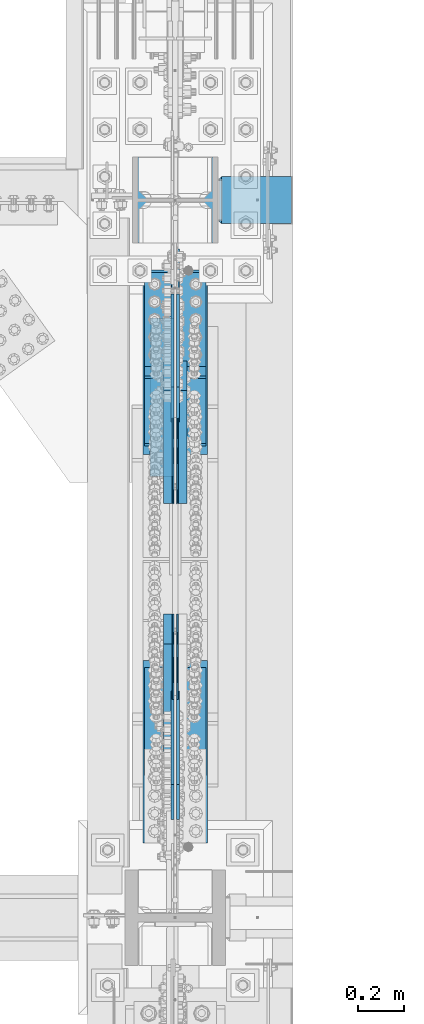
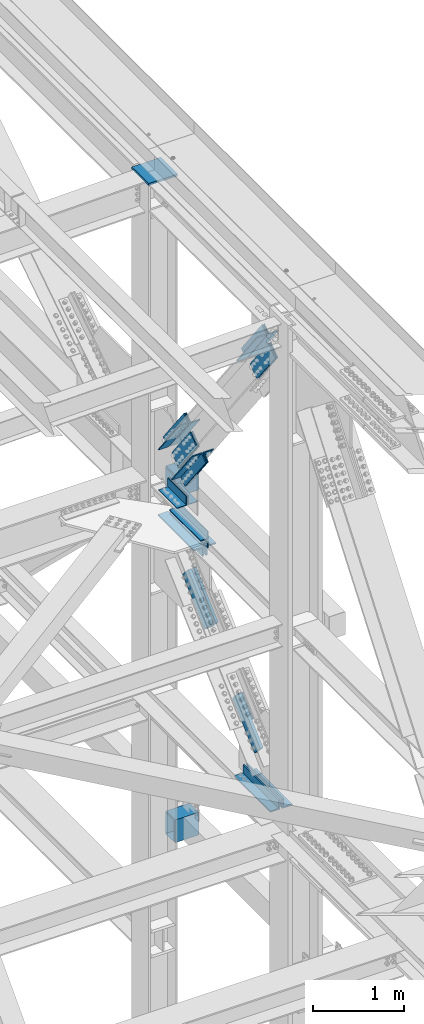
# One storey, part 2776 of 3843: 17 members, 11 beams, 10 elements without a shape of their own.
"""IFC2X3 building model written with IfcOpenShell, lengths in millimetres."""

from ifc_helpers import new_model, si_unit, frame, origin_with_axes, place, context, subcontext, project, spatial, faceted_brep, material, type_object, element, aggregate, save


model = new_model("IFC2X3")

# Units and contexts
model_context = context("Model", 3, precision=1e-05, world=origin_with_axes())
body_context = subcontext(model_context, "Body", "Model", "MODEL_VIEW")
ifc_project = project(units=[si_unit("LENGTHUNIT", "METRE", prefix="MILLI"), si_unit("AREAUNIT", "SQUARE_METRE"), si_unit("VOLUMEUNIT", "CUBIC_METRE"), si_unit("MASSUNIT", "GRAM", prefix="KILO"), si_unit("TIMEUNIT", "SECOND"), si_unit("PLANEANGLEUNIT", "RADIAN"), si_unit("SOLIDANGLEUNIT", "STERADIAN"), si_unit("THERMODYNAMICTEMPERATUREUNIT", "DEGREE_CELSIUS"), si_unit("LUMINOUSINTENSITYUNIT", "LUMEN")], contexts=[model_context])

# Site, building, storey
site_placement = place(None, origin_with_axes())
site = spatial("IfcSite", under=ifc_project, at=site_placement, CompositionType="ELEMENT")
building_placement = place(site_placement, origin_with_axes())
building = spatial("IfcBuilding", under=site, at=building_placement, Name="Undefined", CompositionType="ELEMENT")
storey_placement = place(building_placement, origin_with_axes())
storey = spatial("IfcBuildingStorey", under=building, at=storey_placement, Name="Undefined", CompositionType="ELEMENT", Elevation=0.0)

# Assembly, beam
assembly_1_placement = place(storey_placement, origin_with_axes())
assembly_1 = element("IfcElementAssembly", 1, at=assembly_1_placement, inside=storey, Name="PLATE", AssemblyPlace="NOTDEFINED", PredefinedType="RIGID_FRAME")
ifc_material_1 = material(Name="STEEL/A572-50")
beam_type_1 = type_object("IfcBeamType", Name="L4X4X1/2", PredefinedType="NOTDEFINED")
beam_1_placement = place(assembly_1_placement, frame((85591.650000015, 91020.9, 42297.3494995117), z_axis=(-1.0, 0.0, 0.0), x_axis=(0.0, 1.0, 0.0)))
beam_1 = element("IfcBeam", 2, at=beam_1_placement, type_object=beam_type_1, material=ifc_material_1, Name="ANGLE", ObjectType="L4X4X1/2", context=body_context, shape_type="Brep", body=[
    faceted_brep([(0.0, 50.8000000000029, -50.8000000000029), (0.0, 50.8000000000029, 50.8000000000029), (685.800000000003, 50.8000000000029, 50.8000000000029), (685.800000000003, 50.8000000000029, -50.8000000000029), (0.0, 38.0999999999985, 50.8000000000029), (685.800000000003, 38.0999999999985, 50.8000000000029), (0.0, 38.0999999999985, -38.0999999999985), (685.800000000003, 38.0999999999985, -38.1000000000058), (0.0, -50.8000000000029, -38.1000000000058), (685.800000000003, -50.8000000000029, -38.1000000000058), (0.0, -50.8000000000029, -50.8000000000029), (685.800000000003, -50.8000000000029, -50.8000000000029)], [[[0, 1, 2, 3]], [[1, 4, 5, 2]], [[4, 6, 7, 5]], [[6, 8, 9, 7]], [[8, 10, 11, 9]], [[10, 0, 3, 11]], [[5, 7, 9, 11, 3, 2]], [[10, 8, 6, 4, 1, 0]]]),
])

# Assembly, beams
assembly_2_placement = place(storey_placement, origin_with_axes())
assembly_2 = element("IfcElementAssembly", 3, at=assembly_2_placement, inside=storey, Name="COLUMN", AssemblyPlace="NOTDEFINED", PredefinedType="RIGID_FRAME")
ifc_material_2 = material()
beam_type_2 = type_object("IfcBeamType", Name="HSS12X8X3/8", PredefinedType="NOTDEFINED")
beam_2_placement = place(assembly_2_placement, frame((85832.95, 92214.7, 42214.8), z_axis=(0.0, 0.0, 1.0), x_axis=(1.0, 0.0, 0.0)))
beam_2 = element("IfcBeam", 4, at=beam_2_placement, type_object=beam_type_2, material=ifc_material_2, Name="GIRT", ObjectType="HSS12X8X3/8", context=body_context, shape_type="Brep", body=[
    faceted_brep([(15.8750001309381, 101.600000000006, 152.399999999972), (15.8749984899478, 101.600000000006, -152.400000000031), (6.35000000002037, 92.0749999999971, -142.875), (6.35000000002037, 92.0749999999971, 142.875), (15.8749984899478, -101.600000000006, -152.400000000031), (6.35000000002037, -92.0749999999971, -142.875), (15.8750001044536, -101.600000052975, 152.399999973481), (6.35000000002037, -92.0749999999971, 142.875), (317.499999999971, -101.599999999999, 152.400000000001), (317.499999999971, 101.599999999999, 152.400000000001), (317.499999999971, -101.599999999999, -152.400000000001), (317.499999999971, 101.599999999999, -152.400000000001), (317.499999999971, -92.0750000000007, 142.875), (317.499999999971, 92.0750000000007, 142.875), (317.499999999971, 92.0750000000007, -142.875), (317.499999999971, -92.0750000000007, -142.875)], [[[0, 1, 2, 3]], [[4, 5, 2, 1]], [[6, 7, 5, 4]], [[8, 9, 0, 6]], [[10, 8, 6, 4]], [[11, 10, 4, 1]], [[9, 11, 1, 0]], [[8, 10, 11, 9], [12, 13, 14, 15]], [[14, 13, 3, 2]], [[15, 14, 2, 5]], [[12, 15, 5, 7]], [[13, 12, 7, 3]], [[0, 3, 7, 6]]]),
])
beam_3_placement = place(assembly_2_placement, frame((85832.95, 92214.7, 37592.0), z_axis=(0.0, 0.0, 1.0), x_axis=(1.0, 0.0, 0.0)))
beam_3 = element("IfcBeam", 5, at=beam_3_placement, type_object=beam_type_2, material=ifc_material_2, Name="BEAM", ObjectType="HSS12X8X3/8", context=body_context, shape_type="Brep", body=[
    faceted_brep([(15.8750001309381, 101.600000000006, 152.399999999972), (15.8749984899478, 101.600000000006, -152.400000000031), (6.35000000002037, 92.0749999999971, -142.875), (6.35000000002037, 92.0749999999971, 142.875), (15.8749984899478, -101.600000000006, -152.400000000031), (6.35000000002037, -92.0749999999971, -142.875), (15.8750001044536, -101.600000052975, 152.399999973481), (6.35000000002037, -92.0749999999971, 142.875), (317.499999999971, -101.599999999999, 152.400000000001), (317.499999999971, 101.599999999999, 152.400000000001), (317.499999999971, -101.599999999999, -152.400000000001), (317.499999999971, 101.599999999999, -152.400000000001), (317.499999999971, -92.0750000000007, 142.875), (317.499999999971, 92.0750000000007, 142.875), (317.499999999971, 92.0750000000007, -142.875), (317.499999999971, -92.0750000000007, -142.875)], [[[0, 1, 2, 3]], [[4, 5, 2, 1]], [[6, 7, 5, 4]], [[8, 9, 0, 6]], [[10, 8, 6, 4]], [[11, 10, 4, 1]], [[9, 11, 1, 0]], [[8, 10, 11, 9], [12, 13, 14, 15]], [[14, 13, 3, 2]], [[15, 14, 2, 5]], [[12, 15, 5, 7]], [[13, 12, 7, 3]], [[0, 3, 7, 6]]]),
])

# Beam
beam_type_3 = type_object("IfcBeamType", Name="L4X3-1/2X1/2", PredefinedType="NOTDEFINED")
beam_4_placement = place(assembly_1_placement, frame((85591.6500000149, 91706.7, 42173.5244995117), z_axis=(-1.0, 0.0, 0.0), x_axis=(0.0, -1.0, 0.0)))
beam_4 = element("IfcBeam", 6, at=beam_4_placement, type_object=beam_type_3, material=ifc_material_1, Name="ANGLE", ObjectType="L4X3-1/2X1/2", context=body_context, shape_type="Brep", body=[
    faceted_brep([(0.0, 44.4499999999971, -50.8000000000029), (0.0, 44.4499999999971, 50.8000000000029), (685.800000000003, 44.4499999999971, 50.8000000000029), (685.800000000003, 44.4499999999971, -50.8000000000029), (0.0, 31.75, 50.8000000000029), (685.800000000003, 31.75, 50.8000000000029), (0.0, 31.7500000838336, -38.0999999999985), (685.800000000003, 31.75, -38.0999999999985), (4.36557456851006e-11, -44.4500000000226, -38.0999999999985), (685.800000000003, -44.4499999999971, -38.0999999999985), (0.0, -44.4499999999971, -50.8000000000029), (685.800000000003, -44.4499999999971, -50.8000000000029)], [[[0, 1, 2, 3]], [[1, 4, 5, 2]], [[4, 6, 7, 5]], [[6, 8, 9, 7]], [[8, 10, 11, 9]], [[10, 0, 3, 11]], [[5, 7, 9, 11, 3, 2]], [[10, 8, 6, 4, 1, 0]]]),
])

aggregate(assembly_1, [beam_4, beam_1])

# Assembly, members
assembly_3_placement = place(storey_placement, origin_with_axes())
assembly_3 = element("IfcElementAssembly", 7, at=assembly_3_placement, inside=storey, AssemblyPlace="NOTDEFINED", PredefinedType="RIGID_FRAME")
member_type_1 = type_object("IfcMemberType", PredefinedType="NOTDEFINED")
member_1_placement = place(assembly_3_placement, frame((85617.0500002308, 89873.9391315324, 40116.841340106), z_axis=(0.0, -0.672974507774418, 0.739665675752079), x_axis=(0.0, 0.739665675752077, 0.672974507774421)))
member_1 = element("IfcMember", 8, at=member_1_placement, type_object=member_type_1, material=ifc_material_1, Name="PLATE", context=body_context, shape_type="Brep", body=[
    faceted_brep([(1.16415321826935e-10, 19.0500000000029, -95.2500000001601), (-1.16415321826935e-10, 19.0500000000029, 95.2500000001601), (660.400000008245, 19.0500000000029, 95.2500000025429), (660.400000007954, 19.0500000000029, -95.2499999980901), (-1.16415321826935e-10, -19.0500000000029, 95.2500000001601), (660.400000008245, -19.0500000000029, 95.2500000025429), (1.16415321826935e-10, -19.0500000000029, -95.2500000001601), (660.400000007954, -19.0500000000029, -95.2499999980901)], [[[0, 1, 2, 3]], [[1, 4, 5, 2]], [[4, 6, 7, 5]], [[6, 0, 3, 7]], [[5, 7, 3, 2]], [[6, 4, 1, 0]]]),
])
member_2_placement = place(assembly_3_placement, frame((85680.5500002308, 91456.6608715596, 41556.8586598832), z_axis=(0.0, 0.672974507774426, -0.739665675752072), x_axis=(0.0, -0.739665675752075, -0.672974507774422)))
member_2 = element("IfcMember", 9, at=member_2_placement, type_object=member_type_1, material=ifc_material_1, Name="PLATE", context=body_context, shape_type="Brep", body=[
    faceted_brep([(1.16415321826935e-10, 19.0500000000029, -95.2500000001601), (-1.16415321826935e-10, 19.0500000000029, 95.2500000001601), (660.400000008245, 19.0500000000029, 95.2500000025429), (660.400000007954, 19.0500000000029, -95.2499999980901), (-1.16415321826935e-10, -19.0500000000029, 95.2500000001601), (660.400000008245, -19.0500000000029, 95.2500000025429), (1.16415321826935e-10, -19.0500000000029, -95.2500000001601), (660.400000007954, -19.0500000000029, -95.2499999980901)], [[[0, 1, 2, 3]], [[1, 4, 5, 2]], [[4, 6, 7, 5]], [[6, 0, 3, 7]], [[5, 7, 3, 2]], [[6, 4, 1, 0]]]),
])
member_3_placement = place(assembly_3_placement, frame((85617.0500002308, 91456.6608715596, 41556.8586598832), z_axis=(0.0, 0.672974507774426, -0.739665675752072), x_axis=(0.0, -0.739665675752075, -0.672974507774422)))
member_3 = element("IfcMember", 10, at=member_3_placement, type_object=member_type_1, material=ifc_material_1, Name="PLATE", context=body_context, shape_type="Brep", body=[
    faceted_brep([(1.16415321826935e-10, 19.0500000000029, -95.2500000001601), (-1.16415321826935e-10, 19.0500000000029, 95.2500000001601), (660.400000008245, 19.0500000000029, 95.2500000025429), (660.400000007954, 19.0500000000029, -95.2499999980901), (-1.16415321826935e-10, -19.0500000000029, 95.2500000001601), (660.400000008245, -19.0500000000029, 95.2500000025429), (1.16415321826935e-10, -19.0500000000029, -95.2500000001601), (660.400000007954, -19.0500000000029, -95.2499999980901)], [[[0, 1, 2, 3]], [[1, 4, 5, 2]], [[4, 6, 7, 5]], [[6, 0, 3, 7]], [[5, 7, 3, 2]], [[6, 4, 1, 0]]]),
])

assembly_4_placement = place(storey_placement, origin_with_axes())
assembly_4 = element("IfcElementAssembly", 11, at=assembly_4_placement, inside=storey, AssemblyPlace="NOTDEFINED", PredefinedType="RIGID_FRAME")
member_type_2 = type_object("IfcMemberType", Name="L5X5X1/2", PredefinedType="NOTDEFINED")
member_4_placement = place(assembly_4_placement, frame((85718.6499996898, 91570.2075713451, 42688.2572103369), z_axis=(0.0, -0.792438093282077, -0.609952349217106), x_axis=(0.0, -0.609952349217105, 0.792438093282078)))
member_4 = element("IfcMember", 12, at=member_4_placement, type_object=member_type_2, material=ifc_material_1, Name="ANGLE", ObjectType="L5X5X1/2", context=body_context, shape_type="Brep", body=[
    faceted_brep([(-1.01863406598568e-10, 63.5, -63.5000000002037), (1.01863406598568e-10, 63.5, 63.5000000002074), (749.300000016152, 63.5, 63.4999999992142), (749.300000016028, 63.5, -63.5000000006548), (1.01863406598568e-10, 50.8000000000029, 63.5000000002074), (749.300000016152, 50.8000000000029, 63.4999999992142), (0.0, 50.8000000000029, -50.8000000000029), (749.30000001605, 50.8000000000029, -50.8000000006577), (-7.27595761418343e-11, -63.5, -50.8000000001666), (749.30000001605, -63.5, -50.8000000006577), (-1.01863406598568e-10, -63.5, -63.5000000002037), (749.300000016028, -63.5, -63.5000000006548)], [[[0, 1, 2, 3]], [[1, 4, 5, 2]], [[4, 6, 7, 5]], [[6, 8, 9, 7]], [[8, 10, 11, 9]], [[10, 0, 3, 11]], [[5, 7, 9, 11, 3, 2]], [[10, 8, 6, 4, 1, 0]]]),
])
member_5_placement = place(assembly_4_placement, frame((85718.6499996898, 91495.6008998966, 43576.3940773595), z_axis=(0.0, 0.792438093282068, 0.609952349217117), x_axis=(0.0, 0.6099523492171, -0.792438093282081)))
member_5 = element("IfcMember", 13, at=member_5_placement, type_object=member_type_2, material=ifc_material_1, Name="ANGLE", ObjectType="L5X5X1/2", context=body_context, shape_type="Brep", body=[
    faceted_brep([(-1.01863406598568e-10, 63.5, -63.5000000002037), (1.01863406598568e-10, 63.5, 63.5000000002074), (749.300000016152, 63.5, 63.4999999992142), (749.300000016028, 63.5, -63.5000000006548), (1.01863406598568e-10, 50.8000000000029, 63.5000000002074), (749.300000016152, 50.8000000000029, 63.4999999992142), (0.0, 50.8000000000029, -50.8000000000029), (749.30000001605, 50.8000000000029, -50.8000000006577), (-7.27595761418343e-11, -63.5, -50.8000000001666), (749.30000001605, -63.5, -50.8000000006577), (-1.01863406598568e-10, -63.5, -63.5000000002037), (749.300000016028, -63.5, -63.5000000006548)], [[[0, 1, 2, 3]], [[1, 4, 5, 2]], [[4, 6, 7, 5]], [[6, 8, 9, 7]], [[8, 10, 11, 9]], [[10, 0, 3, 11]], [[5, 7, 9, 11, 3, 2]], [[10, 8, 6, 4, 1, 0]]]),
])
member_6_placement = place(assembly_4_placement, frame((85578.9499996898, 91113.1702760806, 43282.0310736293), z_axis=(0.0, -0.792438093282077, -0.609952349217106), x_axis=(0.0, 0.6099523492171, -0.792438093282081)))
member_6 = element("IfcMember", 14, at=member_6_placement, type_object=member_type_2, material=ifc_material_1, Name="ANGLE", ObjectType="L5X5X1/2", context=body_context, shape_type="Brep", body=[
    faceted_brep([(-1.01863406598568e-10, 63.5, -63.5000000002037), (1.01863406598568e-10, 63.5, 63.5000000002074), (749.300000016152, 63.5, 63.4999999992142), (749.300000016028, 63.5, -63.5000000006548), (1.01863406598568e-10, 50.8000000000029, 63.5000000002074), (749.300000016152, 50.8000000000029, 63.4999999992142), (0.0, 50.8000000000029, -50.8000000000029), (749.30000001605, 50.8000000000029, -50.8000000006577), (-7.27595761418343e-11, -63.5, -50.8000000001666), (749.30000001605, -63.5, -50.8000000006577), (-1.01863406598568e-10, -63.5, -63.5000000002037), (749.300000016028, -63.5, -63.5000000006548)], [[[0, 1, 2, 3]], [[1, 4, 5, 2]], [[4, 6, 7, 5]], [[6, 8, 9, 7]], [[8, 10, 11, 9]], [[10, 0, 3, 11]], [[5, 7, 9, 11, 3, 2]], [[10, 8, 6, 4, 1, 0]]]),
])
member_7_placement = place(assembly_4_placement, frame((85578.9499996898, 91952.6381951611, 42982.6202140671), z_axis=(0.0, 0.792438093282068, 0.609952349217117), x_axis=(0.0, -0.609952349217105, 0.792438093282078)))
member_7 = element("IfcMember", 15, at=member_7_placement, type_object=member_type_2, material=ifc_material_1, Name="ANGLE", ObjectType="L5X5X1/2", context=body_context, shape_type="Brep", body=[
    faceted_brep([(-1.01863406598568e-10, 63.5, -63.5000000002037), (1.01863406598568e-10, 63.5, 63.5000000002074), (749.300000016152, 63.5, 63.4999999992142), (749.300000016028, 63.5, -63.5000000006548), (1.01863406598568e-10, 50.8000000000029, 63.5000000002074), (749.300000016152, 50.8000000000029, 63.4999999992142), (0.0, 50.8000000000029, -50.8000000000029), (749.30000001605, 50.8000000000029, -50.8000000006577), (-7.27595761418343e-11, -63.5, -50.8000000001666), (749.30000001605, -63.5, -50.8000000006577), (-1.01863406598568e-10, -63.5, -63.5000000002037), (749.300000016028, -63.5, -63.5000000006548)], [[[0, 1, 2, 3]], [[1, 4, 5, 2]], [[4, 6, 7, 5]], [[6, 8, 9, 7]], [[8, 10, 11, 9]], [[10, 0, 3, 11]], [[5, 7, 9, 11, 3, 2]], [[10, 8, 6, 4, 1, 0]]]),
])
member_8_placement = place(assembly_4_placement, frame((85718.6499996898, 89779.9432164986, 45805.3427896673), z_axis=(0.0, 0.792438093282068, 0.609952349217117), x_axis=(0.0, 0.6099523492171, -0.792438093282081)))
member_8 = element("IfcMember", 16, at=member_8_placement, type_object=member_type_2, material=ifc_material_1, Name="ANGLE", ObjectType="L5X5X1/2", context=body_context, shape_type="Brep", body=[
    faceted_brep([(-1.01863406598568e-10, 63.5, -63.5000000002037), (1.01863406598568e-10, 63.5, 63.5000000002074), (749.300000016152, 63.5, 63.4999999992142), (749.300000016028, 63.5, -63.5000000006548), (1.01863406598568e-10, 50.8000000000029, 63.5000000002074), (749.300000016152, 50.8000000000029, 63.4999999992142), (0.0, 50.8000000000029, -50.8000000000029), (749.30000001605, 50.8000000000029, -50.8000000006577), (-7.27595761418343e-11, -63.5, -50.8000000001666), (749.30000001605, -63.5, -50.8000000006577), (-1.01863406598568e-10, -63.5, -63.5000000002037), (749.300000016028, -63.5, -63.5000000006548)], [[[0, 1, 2, 3]], [[1, 4, 5, 2]], [[4, 6, 7, 5]], [[6, 8, 9, 7]], [[8, 10, 11, 9]], [[10, 0, 3, 11]], [[5, 7, 9, 11, 3, 2]], [[10, 8, 6, 4, 1, 0]]]),
])
member_9_placement = place(assembly_4_placement, frame((85578.9499996898, 90236.9805117632, 45211.5689263749), z_axis=(0.0, 0.792438093282068, 0.609952349217117), x_axis=(0.0, -0.609952349217105, 0.792438093282078)))
member_9 = element("IfcMember", 17, at=member_9_placement, type_object=member_type_2, material=ifc_material_1, Name="ANGLE", ObjectType="L5X5X1/2", context=body_context, shape_type="Brep", body=[
    faceted_brep([(-1.01863406598568e-10, 63.5, -63.5000000002037), (1.01863406598568e-10, 63.5, 63.5000000002074), (749.300000016152, 63.5, 63.4999999992142), (749.300000016028, 63.5, -63.5000000006548), (1.01863406598568e-10, 50.8000000000029, 63.5000000002074), (749.300000016152, 50.8000000000029, 63.4999999992142), (0.0, 50.8000000000029, -50.8000000000029), (749.30000001605, 50.8000000000029, -50.8000000006577), (-7.27595761418343e-11, -63.5, -50.8000000001666), (749.30000001605, -63.5, -50.8000000006577), (-1.01863406598568e-10, -63.5, -63.5000000002037), (749.300000016028, -63.5, -63.5000000006548)], [[[0, 1, 2, 3]], [[1, 4, 5, 2]], [[4, 6, 7, 5]], [[6, 8, 9, 7]], [[8, 10, 11, 9]], [[10, 0, 3, 11]], [[5, 7, 9, 11, 3, 2]], [[10, 8, 6, 4, 1, 0]]]),
])

# Member
member_type_3 = type_object("IfcMemberType", PredefinedType="NOTDEFINED")
member_10_placement = place(assembly_3_placement, frame((85658.3250002308, 90122.8736147023, 40343.330910695), z_axis=(0.0, -0.672974507774418, 0.739665675752079), x_axis=(0.0, 0.739665675752077, 0.672974507774421)))
member_10 = element("IfcMember", 18, at=member_10_placement, type_object=member_type_3, material=ifc_material_1, Name="PLATE", context=body_context, shape_type="Brep", body=[
    faceted_brep([(0.0, 3.17499999999927, -95.25), (-2.44140610448085e-05, 3.17500000000291, 95.2499999999927), (323.850000004109, 3.17500000000291, 95.2500000014152), (323.850000003833, 3.17500000000291, -95.2499999992106), (0.0, -3.17499999999927, 95.25), (323.850000004109, -3.17500000000291, 95.2500000014152), (0.0, -3.17499999999927, -95.25), (323.850000003833, -3.17500000000291, -95.2499999992106)], [[[0, 1, 2, 3]], [[1, 4, 5, 2]], [[4, 6, 7, 5]], [[6, 0, 3, 7]], [[5, 7, 3, 2]], [[6, 4, 1, 0]]]),
])

member_11_placement = place(assembly_3_placement, frame((85639.2750002308, 90122.8736147023, 40343.330910695), z_axis=(0.0, -0.672974507774418, 0.739665675752079), x_axis=(0.0, 0.739665675752077, 0.672974507774421)))
member_11 = element("IfcMember", 19, at=member_11_placement, type_object=member_type_3, material=ifc_material_1, Name="PLATE", context=body_context, shape_type="Brep", body=[
    faceted_brep([(0.0, 3.17499999999927, -95.25), (-2.44140610448085e-05, 3.17500000000291, 95.2499999999927), (323.850000004109, 3.17500000000291, 95.2500000014152), (323.850000003833, 3.17500000000291, -95.2499999992106), (0.0, -3.17499999999927, 95.25), (323.850000004109, -3.17500000000291, 95.2500000014152), (0.0, -3.17499999999927, -95.25), (323.850000003833, -3.17500000000291, -95.2499999992106)], [[[0, 1, 2, 3]], [[1, 4, 5, 2]], [[4, 6, 7, 5]], [[6, 0, 3, 7]], [[5, 7, 3, 2]], [[6, 4, 1, 0]]]),
])

member_12_placement = place(assembly_3_placement, frame((85658.3250002308, 91207.7263883897, 41330.3690892942), z_axis=(0.0, 0.672974507774426, -0.739665675752072), x_axis=(0.0, -0.739665675752075, -0.672974507774422)))
member_12 = element("IfcMember", 20, at=member_12_placement, type_object=member_type_3, material=ifc_material_1, Name="PLATE", context=body_context, shape_type="Brep", body=[
    faceted_brep([(0.0, 3.17499999999927, -95.25), (-2.44140610448085e-05, 3.17500000000291, 95.2499999999927), (323.850000004109, 3.17500000000291, 95.2500000014152), (323.850000003833, 3.17500000000291, -95.2499999992106), (0.0, -3.17499999999927, 95.25), (323.850000004109, -3.17500000000291, 95.2500000014152), (0.0, -3.17499999999927, -95.25), (323.850000003833, -3.17500000000291, -95.2499999992106)], [[[0, 1, 2, 3]], [[1, 4, 5, 2]], [[4, 6, 7, 5]], [[6, 0, 3, 7]], [[5, 7, 3, 2]], [[6, 4, 1, 0]]]),
])

member_13_placement = place(assembly_3_placement, frame((85639.2750002308, 91207.7263883897, 41330.3690892942), z_axis=(0.0, 0.672974507774426, -0.739665675752072), x_axis=(0.0, -0.739665675752075, -0.672974507774422)))
member_13 = element("IfcMember", 21, at=member_13_placement, type_object=member_type_3, material=ifc_material_1, Name="PLATE", context=body_context, shape_type="Brep", body=[
    faceted_brep([(0.0, 3.17499999999927, -95.25), (-2.44140610448085e-05, 3.17500000000291, 95.2499999999927), (323.850000004109, 3.17500000000291, 95.2500000014152), (323.850000003833, 3.17500000000291, -95.2499999992106), (0.0, -3.17499999999927, 95.25), (323.850000004109, -3.17500000000291, 95.2500000014152), (0.0, -3.17499999999927, -95.25), (323.850000003833, -3.17500000000291, -95.2499999992106)], [[[0, 1, 2, 3]], [[1, 4, 5, 2]], [[4, 6, 7, 5]], [[6, 0, 3, 7]], [[5, 7, 3, 2]], [[6, 4, 1, 0]]]),
])

aggregate(assembly_3, [member_10, member_11, member_1, member_2, member_12, member_13, member_3])

# Assembly, beam
assembly_5_placement = place(storey_placement, origin_with_axes())
assembly_5 = element("IfcElementAssembly", 22, at=assembly_5_placement, inside=storey, Name="ANGLE", AssemblyPlace="NOTDEFINED", PredefinedType="RIGID_FRAME")
beam_type_4 = type_object("IfcBeamType", Name="L5X5X3/4", PredefinedType="NOTDEFINED")
beam_5_placement = place(assembly_5_placement, frame((85725.0000002308, 89438.9562499991, 39649.4000000003), z_axis=(0.0, 0.0, 1.0), x_axis=(0.0, 1.0, 0.0)))
beam_5 = element("IfcBeam", 23, at=beam_5_placement, type_object=beam_type_4, material=ifc_material_1, Name="ANGLE", ObjectType="L5X5X3/4", context=body_context, shape_type="Brep", body=[
    faceted_brep([(-1.01863406598568e-10, 63.5, -63.5000000002037), (1.01863406598568e-10, 63.5, 63.5000000002074), (787.399999999994, 63.5, 63.5), (787.399999999994, 63.5, -63.5), (0.0, 44.4499999999971, 63.5), (787.399999999994, 44.4499999999971, 63.5), (-3.63797880709171e-12, 44.4499999999971, -44.4500000000007), (787.399999999994, 44.4499999999971, -44.4499999999971), (0.0, -63.5, -44.4499999999971), (787.399999999994, -63.5, -44.4499999999971), (-1.01863406598568e-10, -63.5, -63.5000000002037), (787.399999999994, -63.5, -63.5)], [[[0, 1, 2, 3]], [[1, 4, 5, 2]], [[4, 6, 7, 5]], [[6, 8, 9, 7]], [[8, 10, 11, 9]], [[10, 0, 3, 11]], [[5, 7, 9, 11, 3, 2]], [[10, 8, 6, 4, 1, 0]]]),
])
aggregate(assembly_5, [beam_5])

assembly_6_placement = place(storey_placement, origin_with_axes())
assembly_6 = element("IfcElementAssembly", 24, at=assembly_6_placement, inside=storey, Name="ANGLE", AssemblyPlace="NOTDEFINED", PredefinedType="RIGID_FRAME")
beam_6_placement = place(assembly_6_placement, frame((85572.6000002308, 90226.3562499991, 39649.4000000008), z_axis=(0.0, 0.0, 1.0), x_axis=(0.0, -1.0, 0.0)))
beam_6 = element("IfcBeam", 25, at=beam_6_placement, type_object=beam_type_4, material=ifc_material_1, Name="ANGLE", ObjectType="L5X5X3/4", context=body_context, shape_type="Brep", body=[
    faceted_brep([(-1.01863406598568e-10, 63.5, -63.5000000002037), (1.01863406598568e-10, 63.5, 63.5000000002074), (787.399999999994, 63.5, 63.5), (787.399999999994, 63.5, -63.5), (0.0, 44.4499999999971, 63.5), (787.399999999994, 44.4499999999971, 63.5), (-3.63797880709171e-12, 44.4499999999971, -44.4500000000007), (787.399999999994, 44.4499999999971, -44.4499999999971), (0.0, -63.5, -44.4499999999971), (787.399999999994, -63.5, -44.4499999999971), (-1.01863406598568e-10, -63.5, -63.5000000002037), (787.399999999994, -63.5, -63.5)], [[[0, 1, 2, 3]], [[1, 4, 5, 2]], [[4, 6, 7, 5]], [[6, 8, 9, 7]], [[8, 10, 11, 9]], [[10, 0, 3, 11]], [[5, 7, 9, 11, 3, 2]], [[10, 8, 6, 4, 1, 0]]]),
])
aggregate(assembly_6, [beam_6])

assembly_7_placement = place(storey_placement, origin_with_axes())
assembly_7 = element("IfcElementAssembly", 26, at=assembly_7_placement, inside=storey, Name="ANGLE", AssemblyPlace="NOTDEFINED", PredefinedType="RIGID_FRAME")
beam_7_placement = place(assembly_7_placement, frame((85725.000000232, 91902.7562499849, 42024.3000000043), z_axis=(0.0, 0.0, -1.0), x_axis=(0.0, -1.0, 0.0)))
beam_7 = element("IfcBeam", 27, at=beam_7_placement, type_object=beam_type_4, material=ifc_material_1, Name="ANGLE", ObjectType="L5X5X3/4", context=body_context, shape_type="Brep", body=[
    faceted_brep([(-1.01863406598568e-10, 63.5, -63.5000000002037), (1.01863406598568e-10, 63.5, 63.5000000002074), (787.399999999994, 63.5, 63.5), (787.399999999994, 63.5, -63.5), (0.0, 44.4499999999971, 63.5), (787.399999999994, 44.4499999999971, 63.5), (-3.63797880709171e-12, 44.4499999999971, -44.4500000000007), (787.399999999994, 44.4499999999971, -44.4499999999971), (0.0, -63.5, -44.4499999999971), (787.399999999994, -63.5, -44.4499999999971), (-1.01863406598568e-10, -63.5, -63.5000000002037), (787.399999999994, -63.5, -63.5)], [[[0, 1, 2, 3]], [[1, 4, 5, 2]], [[4, 6, 7, 5]], [[6, 8, 9, 7]], [[8, 10, 11, 9]], [[10, 0, 3, 11]], [[5, 7, 9, 11, 3, 2]], [[10, 8, 6, 4, 1, 0]]]),
])
aggregate(assembly_7, [beam_7])

assembly_8_placement = place(storey_placement, origin_with_axes())
assembly_8 = element("IfcElementAssembly", 28, at=assembly_8_placement, inside=storey, Name="ANGLE", AssemblyPlace="NOTDEFINED", PredefinedType="RIGID_FRAME")
beam_8_placement = place(assembly_8_placement, frame((85572.6000002308, 91115.3562499849, 42024.3000000049), z_axis=(0.0, 0.0, -1.0), x_axis=(0.0, 1.0, 0.0)))
beam_8 = element("IfcBeam", 29, at=beam_8_placement, type_object=beam_type_4, material=ifc_material_1, Name="ANGLE", ObjectType="L5X5X3/4", context=body_context, shape_type="Brep", body=[
    faceted_brep([(-1.01863406598568e-10, 63.5, -63.5000000002037), (1.01863406598568e-10, 63.5, 63.5000000002074), (787.399999999994, 63.5, 63.5), (787.399999999994, 63.5, -63.5), (0.0, 44.4499999999971, 63.5), (787.399999999994, 44.4499999999971, 63.5), (-3.63797880709171e-12, 44.4499999999971, -44.4500000000007), (787.399999999994, 44.4499999999971, -44.4499999999971), (0.0, -63.5, -44.4499999999971), (787.399999999994, -63.5, -44.4499999999971), (-1.01863406598568e-10, -63.5, -63.5000000002037), (787.399999999994, -63.5, -63.5)], [[[0, 1, 2, 3]], [[1, 4, 5, 2]], [[4, 6, 7, 5]], [[6, 8, 9, 7]], [[8, 10, 11, 9]], [[10, 0, 3, 11]], [[5, 7, 9, 11, 3, 2]], [[10, 8, 6, 4, 1, 0]]]),
])
aggregate(assembly_8, [beam_8])

# Member
member_type_4 = type_object("IfcMemberType", PredefinedType="NOTDEFINED")
member_14_placement = place(assembly_4_placement, frame((85661.4999996898, 91734.3105013306, 42870.6625854482), z_axis=(0.0, -0.792438093282077, -0.609952349217106), x_axis=(0.0, -0.609952349217105, 0.792438093282078)))
member_14 = element("IfcMember", 30, at=member_14_placement, type_object=member_type_4, material=ifc_material_1, Name="PLATE", context=body_context, shape_type="Brep", body=[
    faceted_brep([(-8.00355337560177e-11, 6.35000000000582, -95.2499999999127), (9.45874489843845e-11, 6.35000000000582, 95.2499999998981), (660.399999994639, 6.35000000000582, 95.249999999287), (660.399999994457, 6.35000000000582, -95.2500000005239), (9.45874489843845e-11, -6.35000000000582, 95.2499999998981), (660.399999994639, -6.35000000000582, 95.249999999287), (-8.00355337560177e-11, -6.35000000000582, -95.2499999999127), (660.399999994457, -6.35000000000582, -95.2500000005239)], [[[0, 1, 2, 3]], [[1, 4, 5, 2]], [[4, 6, 7, 5]], [[6, 0, 3, 7]], [[5, 7, 3, 2]], [[6, 4, 1, 0]]]),
])

member_15_placement = place(assembly_4_placement, frame((85636.0999996898, 91734.3105013306, 42870.6625854482), z_axis=(0.0, -0.792438093282077, -0.609952349217106), x_axis=(0.0, -0.609952349217105, 0.792438093282078)))
member_15 = element("IfcMember", 31, at=member_15_placement, type_object=member_type_4, material=ifc_material_1, Name="PLATE", context=body_context, shape_type="Brep", body=[
    faceted_brep([(-8.00355337560177e-11, 6.35000000000582, -95.2499999999127), (9.45874489843845e-11, 6.35000000000582, 95.2499999998981), (660.399999994639, 6.35000000000582, 95.249999999287), (660.399999994457, 6.35000000000582, -95.2500000005239), (9.45874489843845e-11, -6.35000000000582, 95.2499999998981), (660.399999994639, -6.35000000000582, 95.249999999287), (-8.00355337560177e-11, -6.35000000000582, -95.2499999999127), (660.399999994457, -6.35000000000582, -95.2500000005239)], [[[0, 1, 2, 3]], [[1, 4, 5, 2]], [[4, 6, 7, 5]], [[6, 0, 3, 7]], [[5, 7, 3, 2]], [[6, 4, 1, 0]]]),
])

member_16_placement = place(assembly_4_placement, frame((85661.4999996898, 89615.8402865131, 45622.937414556), z_axis=(0.0, 0.792438093282068, 0.609952349217117), x_axis=(0.0, 0.6099523492171, -0.792438093282081)))
member_16 = element("IfcMember", 32, at=member_16_placement, type_object=member_type_4, material=ifc_material_1, Name="PLATE", context=body_context, shape_type="Brep", body=[
    faceted_brep([(-8.00355337560177e-11, 6.35000000000582, -95.2499999999127), (9.45874489843845e-11, 6.35000000000582, 95.2499999998981), (660.399999994639, 6.35000000000582, 95.249999999287), (660.399999994457, 6.35000000000582, -95.2500000005239), (9.45874489843845e-11, -6.35000000000582, 95.2499999998981), (660.399999994639, -6.35000000000582, 95.249999999287), (-8.00355337560177e-11, -6.35000000000582, -95.2499999999127), (660.399999994457, -6.35000000000582, -95.2500000005239)], [[[0, 1, 2, 3]], [[1, 4, 5, 2]], [[4, 6, 7, 5]], [[6, 0, 3, 7]], [[5, 7, 3, 2]], [[6, 4, 1, 0]]]),
])

member_17_placement = place(assembly_4_placement, frame((85636.0999996898, 89615.8402865131, 45622.937414556), z_axis=(0.0, 0.792438093282068, 0.609952349217117), x_axis=(0.0, 0.6099523492171, -0.792438093282081)))
member_17 = element("IfcMember", 33, at=member_17_placement, type_object=member_type_4, material=ifc_material_1, Name="PLATE", context=body_context, shape_type="Brep", body=[
    faceted_brep([(-8.00355337560177e-11, 6.35000000000582, -95.2499999999127), (9.45874489843845e-11, 6.35000000000582, 95.2499999998981), (660.399999994639, 6.35000000000582, 95.249999999287), (660.399999994457, 6.35000000000582, -95.2500000005239), (9.45874489843845e-11, -6.35000000000582, 95.2499999998981), (660.399999994639, -6.35000000000582, 95.249999999287), (-8.00355337560177e-11, -6.35000000000582, -95.2499999999127), (660.399999994457, -6.35000000000582, -95.2500000005239)], [[[0, 1, 2, 3]], [[1, 4, 5, 2]], [[4, 6, 7, 5]], [[6, 0, 3, 7]], [[5, 7, 3, 2]], [[6, 4, 1, 0]]]),
])

aggregate(assembly_4, [member_4, member_5, member_14, member_6, member_7, member_15, member_8, member_16, member_9, member_17])

# Assembly, beam
assembly_9_placement = place(storey_placement, origin_with_axes())
assembly_9 = element("IfcElementAssembly", 34, at=assembly_9_placement, inside=storey, Name="ANGLE", AssemblyPlace="NOTDEFINED", PredefinedType="RIGID_FRAME")
beam_type_5 = type_object("IfcBeamType", Name="L5X5X3/8", PredefinedType="NOTDEFINED")
beam_9_placement = place(assembly_9_placement, frame((85718.6499996911, 91496.3562499935, 42468.8000000012), z_axis=(0.0, 0.0, 1.0), x_axis=(0.0, 1.0, 0.0)))
beam_9 = element("IfcBeam", 35, at=beam_9_placement, type_object=beam_type_5, material=ifc_material_1, Name="ANGLE", ObjectType="L5X5X3/8", context=body_context, shape_type="Brep", body=[
    faceted_brep([(-1.01863406598568e-10, 63.5, -63.5000000002037), (1.01863406598568e-10, 63.5, 63.5000000002074), (406.400000000009, 63.5, 63.5), (406.400000000009, 63.5, -63.5), (0.0, 53.9750000000058, 63.5), (406.400000000009, 53.9750000000058, 63.5), (0.0, 53.9750000000058, -53.9749999999985), (406.400000000009, 53.9750000000058, -53.9749999999985), (0.0, -63.5, -53.9749999999985), (406.400000000009, -63.5, -53.9749999999985), (-1.01863406598568e-10, -63.5, -63.5000000002037), (406.400000000009, -63.5, -63.5)], [[[0, 1, 2, 3]], [[1, 4, 5, 2]], [[4, 6, 7, 5]], [[6, 8, 9, 7]], [[8, 10, 11, 9]], [[10, 0, 3, 11]], [[5, 7, 9, 11, 3, 2]], [[10, 8, 6, 4, 1, 0]]]),
])
aggregate(assembly_9, [beam_9])

assembly_10_placement = place(storey_placement, origin_with_axes())
assembly_10 = element("IfcElementAssembly", 36, at=assembly_10_placement, inside=storey, Name="ANGLE", AssemblyPlace="NOTDEFINED", PredefinedType="RIGID_FRAME")
beam_10_placement = place(assembly_10_placement, frame((85578.9499996886, 91902.7562499935, 42468.8000000018), z_axis=(0.0, 0.0, 1.0), x_axis=(0.0, -1.0, 0.0)))
beam_10 = element("IfcBeam", 37, at=beam_10_placement, type_object=beam_type_5, material=ifc_material_1, Name="ANGLE", ObjectType="L5X5X3/8", context=body_context, shape_type="Brep", body=[
    faceted_brep([(-1.01863406598568e-10, 63.5, -63.5000000002037), (1.01863406598568e-10, 63.5, 63.5000000002074), (406.400000000009, 63.5, 63.5), (406.400000000009, 63.5, -63.5), (0.0, 53.9750000000058, 63.5), (406.400000000009, 53.9750000000058, 63.5), (0.0, 53.9750000000058, -53.9749999999985), (406.400000000009, 53.9750000000058, -53.9749999999985), (0.0, -63.5, -53.9749999999985), (406.400000000009, -63.5, -53.9749999999985), (-1.01863406598568e-10, -63.5, -63.5000000002037), (406.400000000009, -63.5, -63.5)], [[[0, 1, 2, 3]], [[1, 4, 5, 2]], [[4, 6, 7, 5]], [[6, 8, 9, 7]], [[8, 10, 11, 9]], [[10, 0, 3, 11]], [[5, 7, 9, 11, 3, 2]], [[10, 8, 6, 4, 1, 0]]]),
])
aggregate(assembly_10, [beam_10])

# Beam
beam_type_6 = type_object("IfcBeamType", PredefinedType="NOTDEFINED")
beam_11_placement = place(assembly_2_placement, frame((85832.95, 92214.7, 46442.3125000001), z_axis=(0.0, 1.0, 0.0), x_axis=(-1.0, 0.0, 0.0)))
beam_11 = element("IfcBeam", 38, at=beam_11_placement, type_object=beam_type_6, material=ifc_material_1, Name="PLATE", context=body_context, shape_type="Brep", body=[
    faceted_brep([(0.0, 14.2874999999985, -185.737499999999), (0.0, 14.2874999999985, 185.737499999999), (368.299999999988, 14.2874999999985, 185.737499999999), (368.299999999988, 14.2874999999985, -185.737499999999), (0.0, -14.2874999999985, 185.737499999999), (368.299999999988, -14.2874999999985, 185.737499999999), (0.0, -14.2874999999985, -185.737499999999), (368.299999999988, -14.2874999999985, -185.737499999999)], [[[0, 1, 2, 3]], [[1, 4, 5, 2]], [[4, 6, 7, 5]], [[6, 0, 3, 7]], [[5, 7, 3, 2]], [[6, 4, 1, 0]]]),
])

aggregate(assembly_2, [beam_11, beam_2, beam_3])

save(model, "model.ifc")
